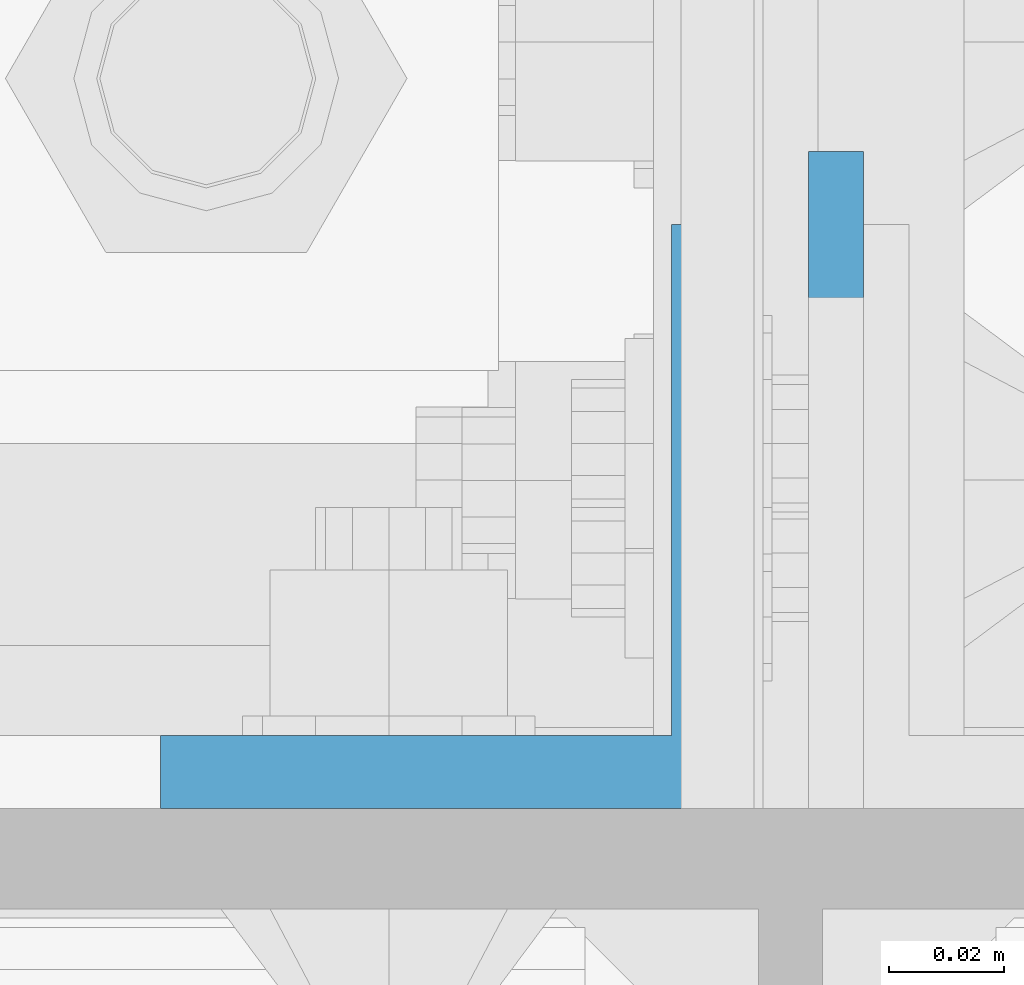
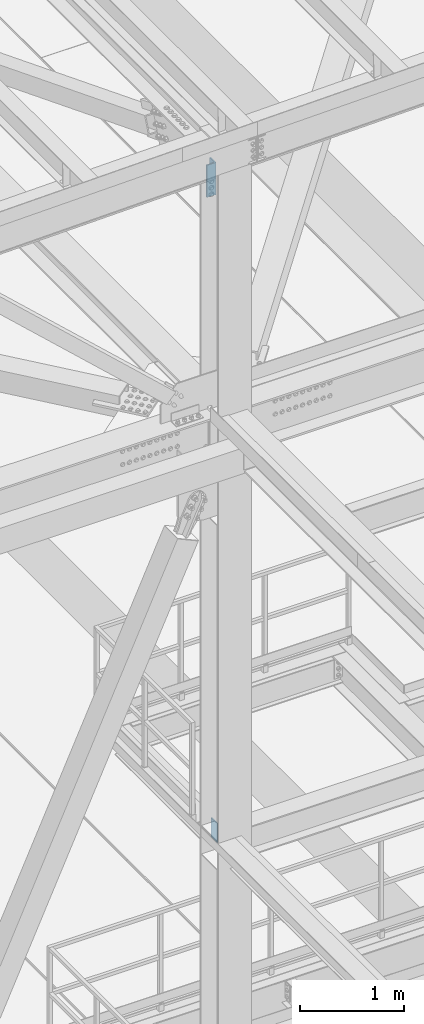
# One storey, part 1484 of 3843: 2 columns, 2 elements without a shape of their own.
"""IFC2X3 building model written with IfcOpenShell, lengths in millimetres."""

from ifc_helpers import new_model, si_unit, frame, origin_with_axes, place, context, subcontext, project, spatial, faceted_brep, material, type_object, element, aggregate, save


model = new_model("IFC2X3")

# Units and contexts
model_context = context("Model", 3, precision=1e-05, world=origin_with_axes())
body_context = subcontext(model_context, "Body", "Model", "MODEL_VIEW")
ifc_project = project(units=[si_unit("LENGTHUNIT", "METRE", prefix="MILLI"), si_unit("AREAUNIT", "SQUARE_METRE"), si_unit("VOLUMEUNIT", "CUBIC_METRE"), si_unit("MASSUNIT", "GRAM", prefix="KILO"), si_unit("TIMEUNIT", "SECOND"), si_unit("PLANEANGLEUNIT", "RADIAN"), si_unit("SOLIDANGLEUNIT", "STERADIAN"), si_unit("THERMODYNAMICTEMPERATUREUNIT", "DEGREE_CELSIUS"), si_unit("LUMINOUSINTENSITYUNIT", "LUMEN")], contexts=[model_context])

# Site, building, storey
site_placement = place(None, origin_with_axes())
site = spatial("IfcSite", under=ifc_project, at=site_placement, CompositionType="ELEMENT")
building_placement = place(site_placement, origin_with_axes())
building = spatial("IfcBuilding", under=site, at=building_placement, Name="Undefined", CompositionType="ELEMENT")
storey_placement = place(building_placement, origin_with_axes())
storey = spatial("IfcBuildingStorey", under=building, at=storey_placement, Name="Undefined", CompositionType="ELEMENT", Elevation=0.0)

# Assembly, column
assembly_1_placement = place(storey_placement, origin_with_axes())
assembly_1 = element("IfcElementAssembly", 1, at=assembly_1_placement, inside=storey, Name="PLATE", AssemblyPlace="NOTDEFINED", PredefinedType="RIGID_FRAME")
ifc_material = material(Name="STEEL/A572-50")
column_type_1 = type_object("IfcColumnType", Name="L4X4X1/2", PredefinedType="NOTDEFINED")
column_1_placement = place(assembly_1_placement, frame((48937.8625, 25844.4999999841, 44821.9146883348), z_axis=(0.0, 1.0, 0.0), x_axis=(0.0, 0.0, 1.0)))
column_1 = element("IfcColumn", 2, at=column_1_placement, type_object=column_type_1, material=ifc_material, Name="ANGLE", ObjectType="L4X4X1/2", context=body_context, shape_type="Brep", body=[
    faceted_brep([(0.0, 50.8000000000029, -50.8000000000029), (0.0, 50.8000000000029, 50.8000000000029), (381.0, 50.8000000000029, 50.8000000000029), (381.0, 50.8000000000029, -50.8000000000029), (0.0, 38.0999999999985, 50.8000000000029), (381.0, 38.0999999999985, 50.8000000000029), (0.0, 38.0999999999985, -38.0999999999985), (381.0, 38.0999999999985, -38.1000000000058), (0.0, -50.8000000000029, -38.1000000000058), (381.0, -50.8000000000029, -38.1000000000058), (0.0, -50.8000000000029, -50.8000000000029), (381.0, -50.8000000000029, -50.8000000000029)], [[[0, 1, 2, 3]], [[1, 4, 5, 2]], [[4, 6, 7, 5]], [[6, 8, 9, 7]], [[8, 10, 11, 9]], [[10, 0, 3, 11]], [[5, 7, 9, 11, 3, 2]], [[10, 8, 6, 4, 1, 0]]]),
])
aggregate(assembly_1, [column_1])

assembly_2_placement = place(storey_placement, origin_with_axes())
assembly_2 = element("IfcElementAssembly", 3, at=assembly_2_placement, inside=storey, Name="COLUMN", AssemblyPlace="NOTDEFINED", PredefinedType="RIGID_FRAME")
column_type_2 = type_object("IfcColumnType", PredefinedType="NOTDEFINED")
column_2_placement = place(assembly_2_placement, frame((49004.5375, 25850.85, 37176.0749999999), z_axis=(0.0, -1.0, 0.0), x_axis=(0.0, 0.0, 1.0)))
column_2 = element("IfcColumn", 4, at=column_2_placement, type_object=column_type_2, material=ifc_material, Name="PLATE", context=body_context, shape_type="Brep", body=[
    faceted_brep([(0.0, 4.76249999999709, -57.1500000000015), (0.0, 4.76249999999709, 57.1500000000015), (228.600000000006, 4.76249999999709, 57.1500000000015), (228.600000000006, 4.76249999999709, -57.1500000000015), (0.0, -4.76249999999709, 57.1500000000015), (228.600000000006, -4.76249999999709, 57.1500000000015), (0.0, -4.76249999999709, -57.1500000000015), (228.600000000006, -4.76249999999709, -57.1500000000015)], [[[0, 1, 2, 3]], [[1, 4, 5, 2]], [[4, 6, 7, 5]], [[6, 0, 3, 7]], [[5, 7, 3, 2]], [[6, 4, 1, 0]]]),
])
aggregate(assembly_2, [column_2])

save(model, "model.ifc")
